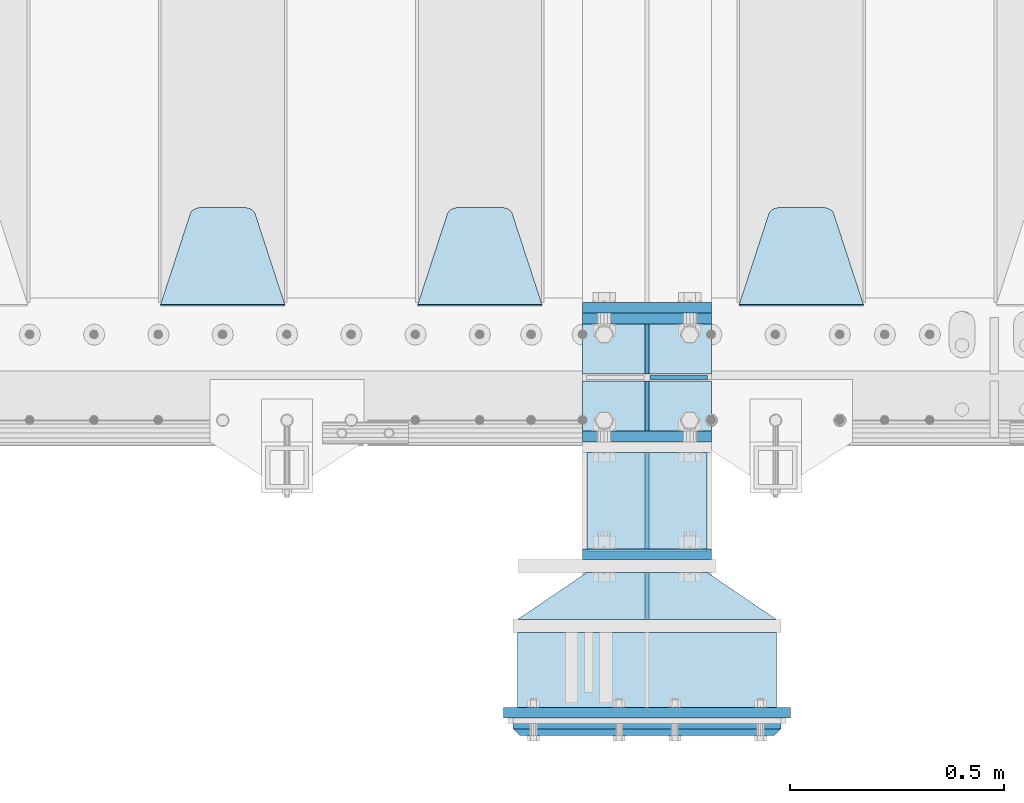
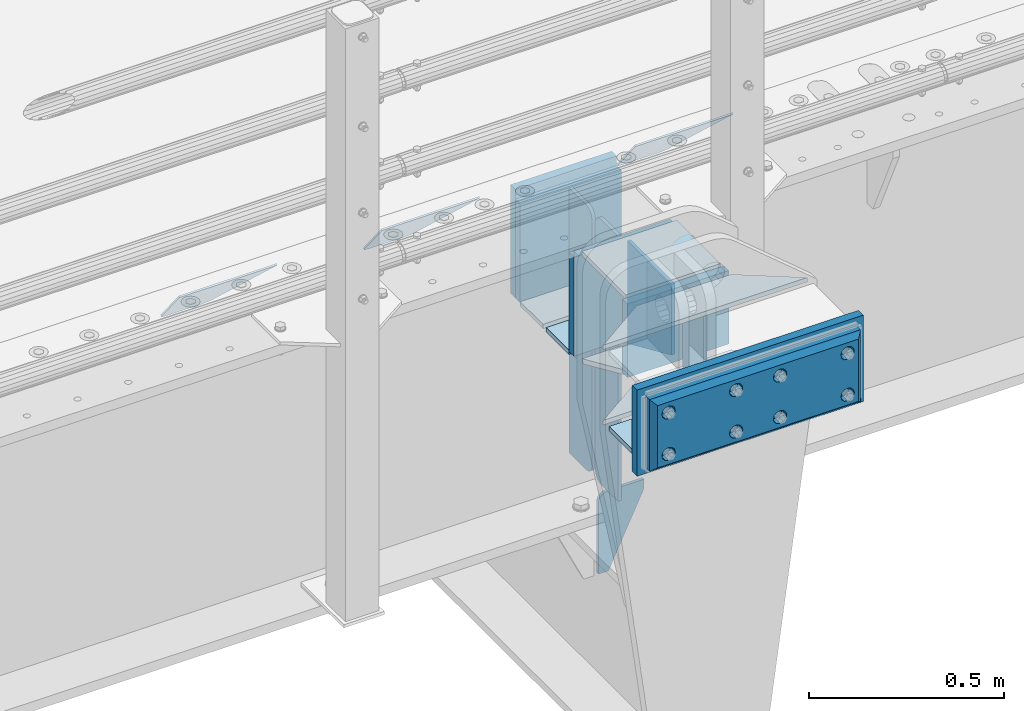
# One storey, part 199 of 240: 23 plates.
"""IFC2X3 building model written with IfcOpenShell, lengths in millimetres."""

from ifc_helpers import new_model, si_unit, frame, origin_with_axes, place, context, subcontext, project, spatial, faceted_brep, material, type_object, element, save


model = new_model("IFC2X3")

# Units and contexts
model_context = context("Model", 3, precision=1e-05, world=origin_with_axes())
body_context = subcontext(model_context, "Body", "Model", "MODEL_VIEW")
ifc_project = project(units=[si_unit("LENGTHUNIT", "METRE", prefix="MILLI"), si_unit("AREAUNIT", "SQUARE_METRE"), si_unit("VOLUMEUNIT", "CUBIC_METRE"), si_unit("MASSUNIT", "GRAM", prefix="KILO"), si_unit("TIMEUNIT", "SECOND"), si_unit("PLANEANGLEUNIT", "RADIAN"), si_unit("SOLIDANGLEUNIT", "STERADIAN"), si_unit("THERMODYNAMICTEMPERATUREUNIT", "DEGREE_CELSIUS"), si_unit("LUMINOUSINTENSITYUNIT", "LUMEN")], contexts=[model_context])

# Site, building, storey
site_placement = place(None, origin_with_axes())
site = spatial("IfcSite", under=ifc_project, at=site_placement, CompositionType="ELEMENT")
building_placement = place(site_placement, origin_with_axes())
building = spatial("IfcBuilding", under=site, at=building_placement, Name="Standard", CompositionType="ELEMENT")
storey_placement = place(building_placement, origin_with_axes())
storey = spatial("IfcBuildingStorey", under=building, at=storey_placement, Name="Undefined", CompositionType="ELEMENT", Elevation=0.0)

# Plates
ifc_material_1 = material(Name="STEEL/S355N")
plate_type_1 = type_object("IfcPlateType", PredefinedType="NOTDEFINED")
plate_1_placement = place(storey_placement, frame((52690.0, 24162.5, -340.000000000044), z_axis=(0.0, 0.0, 1.0), x_axis=(1.0, 0.0, 0.0)))
element("IfcPlate", 1, at=plate_1_placement, inside=storey, type_object=plate_type_1, material=ifc_material_1, context=body_context, shape_type="Brep", body=[
    faceted_brep([(0.0, -12.5, 0.0), (9.31322574615479e-10, -12.5, 340.0), (9.31322574615479e-10, 12.5, 340.0), (0.0, 12.5, 0.0), (300.0, -12.5, 340.0), (300.0, 12.5, 340.0), (300.0, -12.5, 0.0), (300.0, 12.5, 0.0)], [[[0, 1, 2, 3]], [[1, 4, 5, 2]], [[4, 6, 7, 5]], [[6, 0, 3, 7]], [[5, 7, 3, 2]], [[6, 4, 1, 0]]]),
])
for number, where, z_axis, x_axis in (
    (2, (52690.0, 23862.5, -340.0), (0.0, 0.0, 1.0), (1.0, 0.0, 0.0)),
    (3, (52690.0, 24137.5, -340.0), (0.0, 0.0, 1.0), (1.0, 0.0, 0.0)),
):
    element("IfcPlate", number, at=place(storey_placement, frame(where, z_axis=z_axis, x_axis=x_axis)), inside=storey, type_object=plate_type_1, material=ifc_material_1, context=body_context, shape_type="Brep", body=[
        faceted_brep([(0.0, -12.5, 0.0), (0.0, -12.5, 310.0), (0.0, 12.5, 310.0), (0.0, 12.5, 0.0), (300.0, -12.5, 310.0), (300.0, 12.5, 310.0), (300.0, -12.5, 0.0), (300.0, 12.5, 0.0)], [[[0, 1, 2, 3]], [[1, 4, 5, 2]], [[4, 6, 7, 5]], [[6, 0, 3, 7]], [[5, 7, 3, 2]], [[6, 4, 1, 0]]]),
    ])
plate_type_2 = type_object("IfcPlateType", PredefinedType="NOTDEFINED")
for number, where, z_axis, x_axis in (
    (4, (52690.0, 24008.0, -343.0), (0.0, 1.0, 0.0), (1.0, 0.0, 0.0)),
    (5, (52690.0, 23992.0, -343.0), (0.0, -1.0, 0.0), (1.0, 0.0, 0.0)),
):
    element("IfcPlate", number, at=place(storey_placement, frame(where, z_axis=z_axis, x_axis=x_axis)), inside=storey, type_object=plate_type_2, material=ifc_material_1, context=body_context, shape_type="Brep", body=[
        faceted_brep([(0.0, -7.0, 0.0), (0.0, -7.0, 117.0), (0.0, 7.0, 117.0), (0.0, 7.0, 0.0), (300.0, -7.0, 117.0), (300.0, 7.0, 117.0), (300.0, -7.0, 0.0), (300.0, 7.0, 0.0)], [[[0, 1, 2, 3]], [[1, 4, 5, 2]], [[4, 6, 7, 5]], [[6, 0, 3, 7]], [[5, 7, 3, 2]], [[6, 4, 1, 0]]]),
    ])
plate_type_3 = type_object("IfcPlateType", PredefinedType="NOTDEFINED")
for number, where, z_axis, x_axis in (
    (6, (52840.0, 23992.0, -30.0), (0.0, 0.0, -1.0), (0.0, -1.0, 0.0)),
    (7, (52840.0, 24008.0, -30.0), (0.0, 0.0, -1.0), (0.0, 1.0, 0.0)),
):
    element("IfcPlate", number, at=place(storey_placement, frame(where, z_axis=z_axis, x_axis=x_axis)), inside=storey, type_object=plate_type_3, material=ifc_material_1, context=body_context, shape_type="Brep", body=[
        faceted_brep([(0.0, -5.0, 30.0), (0.0, -5.0, 306.0), (0.0, 5.0, 306.0), (0.0, 5.0, 30.0), (117.0, -5.0, 306.0), (117.0, 5.0, 306.0), (117.0, -5.0, 0.0), (117.0, 5.0, 0.0), (30.0, -5.0, 0.0), (30.0, 5.0, 0.0), (24.7905546699913, -5.0, 0.455767409633758), (24.7905546699913, 5.0, 0.455767409633758), (19.7393957002278, -5.0, 1.80922137642275), (19.7393957002278, 5.0, 1.80922137642275), (15.0, -5.0, 4.01923788646684), (15.0, 5.0, 4.01923788646684), (10.7163717094008, -5.0, 7.01866670643066), (10.7163717094008, 5.0, 7.01866670643066), (7.01866670643358, -5.0, 10.7163717094038), (7.01866670643358, 5.0, 10.7163717094038), (4.01923788646673, -5.0, 15.0), (4.01923788646673, 5.0, 15.0), (1.80922137642483, -5.0, 19.7393957002299), (1.80922137642483, 5.0, 19.7393957002299), (0.455767409635882, -5.0, 24.7905546699921), (0.455767409635882, 5.0, 24.7905546699921)], [[[0, 1, 2, 3]], [[1, 4, 5, 2]], [[4, 6, 7, 5]], [[6, 8, 9, 7]], [[8, 10, 11, 9]], [[10, 12, 13, 11]], [[12, 14, 15, 13]], [[14, 16, 17, 15]], [[16, 18, 19, 17]], [[18, 20, 21, 19]], [[20, 22, 23, 21]], [[22, 24, 25, 23]], [[24, 0, 3, 25]], [[5, 7, 9, 11, 13, 15, 17, 19, 21, 23, 25, 3, 2]], [[24, 22, 20, 18, 16, 14, 12, 10, 8, 6, 4, 1, 0]]]),
    ])
for number, where, z_axis, x_axis in (
    (8, (52840.0, 23992.0, -350.0), (0.0, 0.0, -1.0), (0.0, -1.0, 0.0)),
    (9, (52840.0, 24008.0, -350.0), (0.0, 0.0, -1.0), (0.0, 1.0, 0.0)),
):
    element("IfcPlate", number, at=place(storey_placement, frame(where, z_axis=z_axis, x_axis=x_axis)), inside=storey, type_object=plate_type_3, material=ifc_material_1, context=body_context, shape_type="Brep", body=[
        faceted_brep([(0.0, -5.0, 0.0), (0.0, -5.0, 480.0), (0.0, 5.0, 480.0), (0.0, 5.0, 0.0), (0.455767409635882, -5.0, 485.209445330008), (0.455767409635882, 5.0, 485.209445330008), (1.80922137642483, -5.0, 490.26060429977), (1.80922137642483, 5.0, 490.26060429977), (4.01923788646673, -5.0, 495.0), (4.01923788646673, 5.0, 495.0), (7.01866670643358, -5.0, 499.283628290596), (7.01866670643358, 5.0, 499.283628290596), (10.7163717094008, -5.0, 502.981333293569), (10.7163717094008, 5.0, 502.981333293569), (15.0, -5.0, 505.980762113533), (15.0, 5.0, 505.980762113533), (19.7393957002278, -5.0, 508.190778623577), (19.7393957002278, 5.0, 508.190778623577), (24.7905546699913, -5.0, 509.544232590366), (24.7905546699913, 5.0, 509.544232590366), (30.0, -5.0, 510.0), (30.0, 5.0, 510.0), (117.0, -5.0, 510.0), (117.0, 5.0, 510.0), (117.0, -5.0, 0.0), (117.0, 5.0, 0.0)], [[[0, 1, 2, 3]], [[1, 4, 5, 2]], [[4, 6, 7, 5]], [[6, 8, 9, 7]], [[8, 10, 11, 9]], [[10, 12, 13, 11]], [[12, 14, 15, 13]], [[14, 16, 17, 15]], [[16, 18, 19, 17]], [[18, 20, 21, 19]], [[20, 22, 23, 21]], [[22, 24, 25, 23]], [[24, 0, 3, 25]], [[5, 7, 9, 11, 13, 15, 17, 19, 21, 23, 25, 3, 2]], [[24, 22, 20, 18, 16, 14, 12, 10, 8, 6, 4, 1, 0]]]),
    ])
plate_type_4 = type_object("IfcPlateType", PredefinedType="NOTDEFINED")
plate_2_placement = place(storey_placement, frame((52846.5, 24000.0000000345, -915.000018222274), z_axis=(0.0, 0.0, -1.0), x_axis=(1.0, 0.0, 0.0)))
element("IfcPlate", 10, at=plate_2_placement, inside=storey, type_object=plate_type_4, material=ifc_material_1, context=body_context, shape_type="Brep", body=[
    faceted_brep([(0.0, -5.0, 27.0), (0.0, -5.0, 250.0), (0.0, 5.0, 250.0), (0.0, 5.0, 27.0), (30.0, -5.0, 250.0), (30.0, 5.0, 250.0), (135.0, -5.0, 30.0), (135.0, 5.0, 30.0), (135.0, -5.0, 0.0), (135.0, 5.0, 0.0), (27.0, -5.0, 0.0), (27.0, 5.0, 0.0), (22.311499202995, -5.0, 0.410190668670339), (22.311499202995, 5.0, 0.410190668670339), (17.7654561302043, -5.0, 1.62829923878053), (17.7654561302043, 5.0, 1.62829923878053), (13.5, -5.0, 3.6173140978201), (13.5, 5.0, 3.6173140978201), (9.64473453846585, -5.0, 6.31680003578754), (9.64473453846585, 5.0, 6.31680003578754), (6.31680003579095, -5.0, 9.64473453846347), (6.31680003579095, 5.0, 9.64473453846347), (3.61731409782078, -5.0, 13.5), (3.61731409782078, 5.0, 13.5), (1.62829923877871, -5.0, 17.765456130207), (1.62829923877871, 5.0, 17.765456130207), (0.410190668670111, -5.0, 22.3114992029929), (0.410190668670111, 5.0, 22.3114992029929)], [[[0, 1, 2, 3]], [[1, 4, 5, 2]], [[4, 6, 7, 5]], [[6, 8, 9, 7]], [[8, 10, 11, 9]], [[10, 12, 13, 11]], [[12, 14, 15, 13]], [[14, 16, 17, 15]], [[16, 18, 19, 17]], [[18, 20, 21, 19]], [[20, 22, 23, 21]], [[22, 24, 25, 23]], [[24, 26, 27, 25]], [[26, 0, 3, 27]], [[5, 7, 9, 11, 13, 15, 17, 19, 21, 23, 25, 27, 3, 2]], [[26, 24, 22, 20, 18, 16, 14, 12, 10, 8, 6, 4, 1, 0]]]),
])
plate_type_5 = type_object("IfcPlateType", PredefinedType="NOTDEFINED")
plate_3_placement = place(storey_placement, frame((53345.0, 24168.232233047, -1.76776695296758), z_axis=(0.0, 0.707106781186547, -0.707106781186548), x_axis=(-1.0, 0.0, 0.0)))
element("IfcPlate", 11, at=plate_3_placement, inside=storey, type_object=plate_type_5, material=ifc_material_1, context=body_context, shape_type="Brep", body=[
    faceted_brep([(0.0, -2.5, 0.0), (69.345504679477, -2.50000000000364, 300.171731424827), (69.345504679477, 2.49999999999636, 300.171731424827), (0.0, 2.5, 0.0), (70.927406119954, -2.50000000000364, 304.897442415397), (70.927406119954, 2.49999999999636, 304.897442415397), (73.3818627772271, -2.50000000000728, 309.234538108525), (73.3818627772271, 2.49999999999636, 309.234538108529), (76.6187032999587, -2.50000000000728, 313.023683126099), (76.6187032999587, 2.49999999999636, 313.023683126103), (80.5190132705029, -2.50000000000364, 316.125672595368), (80.5190132705029, 2.49999999999636, 316.125672595368), (84.9395038596849, -2.50000000000364, 318.426546230472), (84.9395038596849, 2.49999999999636, 318.426546230472), (89.7177759439219, -2.5, 319.841774983277), (89.7177759439219, 2.49999999999636, 319.841774983273), (94.6782862926484, -2.50000000000364, 320.319366455074), (94.6782862926484, 2.49999999999636, 320.319366455074), (195.321713707352, -2.50000000000364, 320.319366455074), (195.321713707352, 2.49999999999636, 320.319366455074), (200.282224056078, -2.50000000000364, 319.841774983273), (200.282224056078, 2.49999999999636, 319.841774983273), (205.060496140315, -2.50000000000364, 318.426546230472), (205.060496140315, 2.49999999999636, 318.426546230472), (209.480986729497, -2.50000000000364, 316.125672595368), (209.480986729497, 2.49999999999636, 316.125672595368), (213.381296700041, -2.50000000000728, 313.023683126099), (213.381296700041, 2.49999999999272, 313.023683126099), (216.618137222766, -2.50000000000364, 309.234538108522), (216.618137222766, 2.49999999999636, 309.234538108522), (219.072593880039, -2.50000000000364, 304.897442415397), (219.072593880039, 2.49999999999636, 304.897442415397), (220.654495320523, -2.50000000000364, 300.171731424827), (220.654495320523, 2.49999999999636, 300.171731424827), (290.0, -2.50000000000364, -3.63797880709171e-12), (290.0, 2.49999999999636, -3.63797880709171e-12)], [[[0, 1, 2, 3]], [[1, 4, 5, 2]], [[4, 6, 7, 5]], [[6, 8, 9, 7]], [[8, 10, 11, 9]], [[10, 12, 13, 11]], [[12, 14, 15, 13]], [[14, 16, 17, 15]], [[16, 18, 19, 17]], [[18, 20, 21, 19]], [[20, 22, 23, 21]], [[22, 24, 25, 23]], [[24, 26, 27, 25]], [[26, 28, 29, 27]], [[28, 30, 31, 29]], [[30, 32, 33, 31]], [[32, 34, 35, 33]], [[34, 0, 3, 35]], [[5, 7, 9, 11, 13, 15, 17, 19, 21, 23, 25, 27, 29, 31, 33, 35, 3, 2]], [[34, 32, 30, 28, 26, 24, 22, 20, 18, 16, 14, 12, 10, 8, 6, 4, 1, 0]]]),
])
plate_4_placement = place(storey_placement, frame((52595.0, 24168.232233047, -1.76776695296758), z_axis=(0.0, 0.707106781186547, -0.707106781186548), x_axis=(-1.0, 0.0, 0.0)))
element("IfcPlate", 12, at=plate_4_placement, inside=storey, type_object=plate_type_5, material=ifc_material_1, context=body_context, shape_type="Brep", body=[
    faceted_brep([(0.0, -2.5, 0.0), (69.345504679477, -2.50000000000364, 300.171731424827), (69.345504679477, 2.49999999999636, 300.171731424827), (0.0, 2.5, 0.0), (70.927406119954, -2.50000000000364, 304.897442415397), (70.927406119954, 2.49999999999636, 304.897442415397), (73.3818627772271, -2.50000000000728, 309.234538108525), (73.3818627772271, 2.49999999999636, 309.234538108529), (76.6187032999587, -2.50000000000728, 313.023683126099), (76.6187032999587, 2.49999999999636, 313.023683126103), (80.5190132705029, -2.50000000000364, 316.125672595368), (80.5190132705029, 2.49999999999636, 316.125672595368), (84.9395038596849, -2.50000000000364, 318.426546230472), (84.9395038596849, 2.49999999999636, 318.426546230472), (89.7177759439219, -2.5, 319.841774983277), (89.7177759439219, 2.49999999999636, 319.841774983273), (94.6782862926484, -2.50000000000364, 320.319366455074), (94.6782862926484, 2.49999999999636, 320.319366455074), (195.321713707352, -2.50000000000364, 320.319366455074), (195.321713707352, 2.49999999999636, 320.319366455074), (200.282224056078, -2.50000000000364, 319.841774983273), (200.282224056078, 2.49999999999636, 319.841774983273), (205.060496140315, -2.50000000000364, 318.426546230472), (205.060496140315, 2.49999999999636, 318.426546230472), (209.480986729497, -2.50000000000364, 316.125672595368), (209.480986729497, 2.49999999999636, 316.125672595368), (213.381296700041, -2.50000000000728, 313.023683126099), (213.381296700041, 2.49999999999272, 313.023683126099), (216.618137222766, -2.50000000000364, 309.234538108522), (216.618137222766, 2.49999999999636, 309.234538108522), (219.072593880039, -2.50000000000364, 304.897442415397), (219.072593880039, 2.49999999999636, 304.897442415397), (220.654495320523, -2.50000000000364, 300.171731424827), (220.654495320523, 2.49999999999636, 300.171731424827), (290.0, -2.50000000000364, -3.63797880709171e-12), (290.0, 2.49999999999636, -3.63797880709171e-12)], [[[0, 1, 2, 3]], [[1, 4, 5, 2]], [[4, 6, 7, 5]], [[6, 8, 9, 7]], [[8, 10, 11, 9]], [[10, 12, 13, 11]], [[12, 14, 15, 13]], [[14, 16, 17, 15]], [[16, 18, 19, 17]], [[18, 20, 21, 19]], [[20, 22, 23, 21]], [[22, 24, 25, 23]], [[24, 26, 27, 25]], [[26, 28, 29, 27]], [[28, 30, 31, 29]], [[30, 32, 33, 31]], [[32, 34, 35, 33]], [[34, 0, 3, 35]], [[5, 7, 9, 11, 13, 15, 17, 19, 21, 23, 25, 27, 29, 31, 33, 35, 3, 2]], [[34, 32, 30, 28, 26, 24, 22, 20, 18, 16, 14, 12, 10, 8, 6, 4, 1, 0]]]),
])
plate_5_placement = place(storey_placement, frame((51995.0, 24168.232233047, -1.76776695296758), z_axis=(0.0, 0.707106781186547, -0.707106781186548), x_axis=(-1.0, 0.0, 0.0)))
element("IfcPlate", 13, at=plate_5_placement, inside=storey, type_object=plate_type_5, material=ifc_material_1, context=body_context, shape_type="Brep", body=[
    faceted_brep([(0.0, -2.5, 0.0), (69.345504679477, -2.50000000000364, 300.171731424827), (69.345504679477, 2.49999999999636, 300.171731424827), (0.0, 2.5, 0.0), (70.927406119954, -2.50000000000364, 304.897442415397), (70.927406119954, 2.49999999999636, 304.897442415397), (73.3818627772271, -2.50000000000728, 309.234538108525), (73.3818627772271, 2.49999999999636, 309.234538108529), (76.6187032999587, -2.50000000000728, 313.023683126099), (76.6187032999587, 2.49999999999636, 313.023683126103), (80.5190132705029, -2.50000000000364, 316.125672595368), (80.5190132705029, 2.49999999999636, 316.125672595368), (84.9395038596849, -2.50000000000364, 318.426546230472), (84.9395038596849, 2.49999999999636, 318.426546230472), (89.7177759439219, -2.5, 319.841774983277), (89.7177759439219, 2.49999999999636, 319.841774983273), (94.6782862926484, -2.50000000000364, 320.319366455074), (94.6782862926484, 2.49999999999636, 320.319366455074), (195.321713707352, -2.50000000000364, 320.319366455074), (195.321713707352, 2.49999999999636, 320.319366455074), (200.282224056078, -2.50000000000364, 319.841774983273), (200.282224056078, 2.49999999999636, 319.841774983273), (205.060496140315, -2.50000000000364, 318.426546230472), (205.060496140315, 2.49999999999636, 318.426546230472), (209.480986729497, -2.50000000000364, 316.125672595368), (209.480986729497, 2.49999999999636, 316.125672595368), (213.381296700041, -2.50000000000728, 313.023683126099), (213.381296700041, 2.49999999999272, 313.023683126099), (216.618137222766, -2.50000000000364, 309.234538108522), (216.618137222766, 2.49999999999636, 309.234538108522), (219.072593880039, -2.50000000000364, 304.897442415397), (219.072593880039, 2.49999999999636, 304.897442415397), (220.654495320523, -2.50000000000364, 300.171731424827), (220.654495320523, 2.49999999999636, 300.171731424827), (290.0, -2.50000000000364, -3.63797880709171e-12), (290.0, 2.49999999999636, -3.63797880709171e-12)], [[[0, 1, 2, 3]], [[1, 4, 5, 2]], [[4, 6, 7, 5]], [[6, 8, 9, 7]], [[8, 10, 11, 9]], [[10, 12, 13, 11]], [[12, 14, 15, 13]], [[14, 16, 17, 15]], [[16, 18, 19, 17]], [[18, 20, 21, 19]], [[20, 22, 23, 21]], [[22, 24, 25, 23]], [[24, 26, 27, 25]], [[26, 28, 29, 27]], [[28, 30, 31, 29]], [[30, 32, 33, 31]], [[32, 34, 35, 33]], [[34, 0, 3, 35]], [[5, 7, 9, 11, 13, 15, 17, 19, 21, 23, 25, 27, 29, 31, 33, 35, 3, 2]], [[34, 32, 30, 28, 26, 24, 22, 20, 18, 16, 14, 12, 10, 8, 6, 4, 1, 0]]]),
])
ifc_material_2 = material()
plate_type_6 = type_object("IfcPlateType", PredefinedType="NOTDEFINED")
plate_6_placement = place(storey_placement, frame((53142.5, 23405.0000000345, -243.000018222276), z_axis=(0.0, -1.0, 0.0), x_axis=(-1.0, 0.0, 0.0)))
element("IfcPlate", 14, at=plate_6_placement, inside=storey, type_object=plate_type_6, material=ifc_material_2, context=body_context, shape_type="Brep", body=[
    faceted_brep([(0.0, -7.0, 0.0), (0.0, -7.0, 175.0), (0.0, 7.0, 175.0), (0.0, 7.0, 0.0), (605.0, -7.0, 175.0), (605.0, 7.0, 175.0), (605.0, -7.0, 0.0), (605.0, 7.0, 0.0)], [[[0, 1, 2, 3]], [[1, 4, 5, 2]], [[4, 6, 7, 5]], [[6, 0, 3, 7]], [[5, 7, 3, 2]], [[6, 4, 1, 0]]]),
])
plate_type_7 = type_object("IfcPlateType", PredefinedType="NOTDEFINED")
plate_7_placement = place(storey_placement, frame((53175.0, 23217.5000000345, 9.9999817777242), z_axis=(0.0, 0.0, -1.0), x_axis=(-1.0, 0.0, 0.0)))
element("IfcPlate", 15, at=plate_7_placement, inside=storey, type_object=plate_type_7, material=ifc_material_1, context=body_context, shape_type="Brep", body=[
    faceted_brep([(0.0, -12.5, 0.0), (0.0, -12.5, 270.0), (0.0, 12.5, 270.0), (0.0, 12.5, 0.0), (670.0, -12.5, 270.0), (670.0, 12.5, 270.0), (670.0, -12.5, 0.0), (670.0, 12.5, 0.0)], [[[0, 1, 2, 3]], [[1, 4, 5, 2]], [[4, 6, 7, 5]], [[6, 0, 3, 7]], [[5, 7, 3, 2]], [[6, 4, 1, 0]]]),
])
plate_type_8 = type_object("IfcPlateType", PredefinedType="NOTDEFINED")
for number, where, z_axis, x_axis in (
    (16, (53142.5, 23435.0000000345, -243.000018222276), (-0.560566412034006, -0.828109472050236, 0.0), (-0.828109472050235, 0.560566412034008, 0.0)),
    (17, (53142.5, 23435.0000000345, -7.0000182222758), (-0.560566412034006, -0.828109472050236, 0.0), (-0.828109472050235, 0.560566412034008, 0.0)),
):
    element("IfcPlate", number, at=place(storey_placement, frame(where, z_axis=z_axis, x_axis=x_axis)), inside=storey, type_object=plate_type_8, material=ifc_material_1, context=body_context, shape_type="Brep", body=[
        faceted_brep([(0.0, -7.0, 0.0), (501.006225585945, -7.0, 339.142669677733), (501.006225585945, 7.0, 339.142669677733), (0.0, 7.0, 0.0), (428.100738525383, -7.0, 156.958602905272), (428.100738525383, 7.0, 156.958602905272), (196.230087280266, -7.0, -4.34624780609738e-10), (196.230087280266, 7.0, -4.34624780609738e-10)], [[[0, 1, 2, 3]], [[1, 4, 5, 2]], [[4, 6, 7, 5]], [[6, 0, 3, 7]], [[5, 7, 3, 2]], [[6, 4, 1, 0]]]),
    ])
plate_type_9 = type_object("IfcPlateType", PredefinedType="NOTDEFINED")
plate_8_placement = place(storey_placement, frame((52840.0, 23435.0000000345, -14.0000182222758), z_axis=(0.0, 0.0, -1.0), x_axis=(0.0, 1.0, 0.0)))
element("IfcPlate", 18, at=plate_8_placement, inside=storey, type_object=plate_type_9, material=ifc_material_1, context=body_context, shape_type="Brep", body=[
    faceted_brep([(0.0, -5.0, 0.0), (0.0, -5.0, 222.0), (0.0, 5.0, 222.0), (0.0, 5.0, 0.0), (110.0, -5.0, 222.0), (110.0, 5.0, 222.0), (110.0, -5.0, 0.0), (110.0, 5.0, 0.0)], [[[0, 1, 2, 3]], [[1, 4, 5, 2]], [[4, 6, 7, 5]], [[6, 0, 3, 7]], [[5, 7, 3, 2]], [[6, 4, 1, 0]]]),
])
plate_type_10 = type_object("IfcPlateType", PredefinedType="NOTDEFINED")
plate_9_placement = place(storey_placement, frame((52700.0, 23822.1570307734, -342.396699063199), z_axis=(0.0, -0.913811548702731, 0.406138465867881), x_axis=(1.0, 0.0, 0.0)))
element("IfcPlate", 19, at=plate_9_placement, inside=storey, type_object=plate_type_10, material=ifc_material_1, context=body_context, shape_type="Brep", body=[
    faceted_brep([(0.0, -7.0, 0.0), (0.0, -7.0, 246.221450805664), (0.0, 7.0, 246.221450805664), (0.0, 7.0, 0.0), (280.0, -7.0, 246.221450805664), (280.0, 7.0, 246.221450805664), (280.0, -6.99999999999818, 0.0), (280.0, 7.0, 0.0)], [[[0, 1, 2, 3]], [[1, 4, 5, 2]], [[4, 6, 7, 5]], [[6, 0, 3, 7]], [[5, 7, 3, 2]], [[6, 4, 1, 0]]]),
])
ifc_material_3 = material()
plate_type_11 = type_object("IfcPlateType", PredefinedType="NOTDEFINED")
plate_10_placement = place(storey_placement, frame((53152.5, 23185.0000000345, -12.5000182222758), z_axis=(0.0, 0.0, -1.0), x_axis=(-1.0, 0.0, 0.0)))
element("IfcPlate", 20, at=plate_10_placement, inside=storey, type_object=plate_type_11, material=ifc_material_3, context=body_context, shape_type="Brep", body=[
    faceted_brep([(0.0, -5.0, 0.0), (15.0, -20.0, 15.0), (15.0, -20.0, 210.0), (0.0, -5.0, 225.0), (625.0, -5.0, 225.0), (610.0, -20.0, 210.0), (610.0, -20.0, 15.0), (625.0, -5.0, 0.0), (625.0, 15.0, 0.0), (620.0, 20.0, 5.0), (620.0, 20.0, 220.0), (625.0, 15.0, 225.0), (0.0, 15.0, 225.0), (5.0, 20.0, 220.0), (5.0, 20.0, 5.0), (0.0, 15.0, 0.0), (30.1794919243112, 5.0, 167.499999999998), (37.5, 5.0, 160.179491924309), (47.5, 5.0, 157.499999999998), (57.5, 5.0, 160.179491924309), (64.8205080756888, 5.0, 167.499999999998), (67.5, 5.0, 177.499999999998), (64.8205080756888, 5.0, 187.499999999998), (57.5, 5.0, 194.820508075687), (47.5, 5.0, 197.499999999998), (37.5, 5.0, 194.820508075687), (30.1794919243112, 5.0, 187.499999999998), (27.5, 5.0, 177.499999999998), (37.5, -20.0, 160.179491924309), (30.1794919243112, -20.0, 167.499999999998), (47.5, -20.0, 157.499999999998), (57.5, -20.0, 160.179491924309), (64.8205080756888, -20.0, 167.499999999998), (67.5, -20.0, 177.499999999998), (64.8205080756888, -20.0, 187.499999999998), (57.5, -20.0, 194.820508075687), (47.5, -20.0, 197.499999999998), (37.5, -20.0, 194.820508075687), (30.1794919243112, -20.0, 187.499999999998), (27.5, -20.0, 177.499999999998), (30.1794919243112, 5.0, 37.4999999999982), (37.5, 5.0, 30.1794919243094), (47.5, 5.0, 27.4999999999982), (57.5, 5.0, 30.1794919243094), (64.8205080756888, 5.0, 37.4999999999982), (67.5, 5.0, 47.4999999999982), (64.8205080756888, 5.0, 57.4999999999982), (57.5, 5.0, 64.8205080756869), (47.5, 5.0, 67.4999999999982), (37.5, 5.0, 64.820508075687), (30.1794919243112, 5.0, 57.4999999999982), (27.5, 5.0, 47.4999999999982), (30.1794919243112, -20.0, 37.4999999999982), (27.5, -20.0, 47.4999999999982), (37.5, -20.0, 30.1794919243094), (47.5, -20.0, 27.4999999999982), (57.5, -20.0, 30.1794919243094), (64.8205080756888, -20.0, 37.4999999999982), (67.5, -20.0, 47.4999999999982), (64.8205080756888, -20.0, 57.4999999999982), (57.5, -20.0, 64.8205080756869), (47.5, -20.0, 67.4999999999982), (37.5, -20.0, 64.820508075687), (30.1794919243112, -20.0, 57.4999999999982), (230.179491924311, 5.0, 37.4999999999982), (237.5, 5.0, 30.1794919243094), (247.5, 5.0, 27.4999999999982), (257.5, 5.0, 30.1794919243094), (264.820508075689, 5.0, 37.4999999999982), (267.5, 5.0, 47.4999999999982), (264.820508075689, 5.0, 57.4999999999982), (257.5, 5.0, 64.8205080756869), (247.5, 5.0, 67.4999999999982), (237.5, 5.0, 64.820508075687), (230.179491924311, 5.0, 57.4999999999982), (227.5, 5.0, 47.4999999999982), (230.179491924311, -20.0, 37.4999999999982), (227.5, -20.0, 47.4999999999982), (237.5, -20.0, 30.1794919243094), (247.5, -20.0, 27.4999999999982), (257.5, -20.0, 30.1794919243094), (264.820508075689, -20.0, 37.4999999999982), (267.5, -20.0, 47.4999999999982), (264.820508075689, -20.0, 57.4999999999982), (257.5, -20.0, 64.8205080756869), (247.5, -20.0, 67.4999999999982), (237.5, -20.0, 64.820508075687), (230.179491924311, -20.0, 57.4999999999982), (360.179491924311, 5.0, 37.4999999999982), (367.5, 5.0, 30.1794919243094), (377.5, 5.0, 27.4999999999982), (387.5, 5.0, 30.1794919243094), (394.820508075689, 5.0, 37.4999999999982), (397.5, 5.0, 47.4999999999982), (394.820508075689, 5.0, 57.4999999999982), (387.5, 5.0, 64.8205080756869), (377.5, 5.0, 67.4999999999982), (367.5, 5.0, 64.820508075687), (360.179491924311, 5.0, 57.4999999999982), (357.5, 5.0, 47.4999999999982), (360.179491924311, -20.0, 37.4999999999982), (357.5, -20.0, 47.4999999999982), (367.5, -20.0, 30.1794919243094), (377.5, -20.0, 27.4999999999982), (387.5, -20.0, 30.1794919243094), (394.820508075689, -20.0, 37.4999999999982), (397.5, -20.0, 47.4999999999982), (394.820508075689, -20.0, 57.4999999999982), (387.5, -20.0, 64.8205080756869), (377.5, -20.0, 67.4999999999982), (367.5, -20.0, 64.820508075687), (360.179491924311, -20.0, 57.4999999999982), (560.179491924311, 5.0, 37.4999999999982), (567.5, 5.0, 30.1794919243094), (577.5, 5.0, 27.4999999999982), (587.5, 5.0, 30.1794919243094), (594.820508075689, 5.0, 37.4999999999982), (597.5, 5.0, 47.4999999999982), (594.820508075689, 5.0, 57.4999999999982), (587.5, 5.0, 64.8205080756869), (577.5, 5.0, 67.4999999999982), (567.5, 5.0, 64.820508075687), (560.179491924311, 5.0, 57.4999999999982), (557.5, 5.0, 47.4999999999982), (560.179491924311, -20.0, 37.4999999999982), (557.5, -20.0, 47.4999999999982), (567.5, -20.0, 30.1794919243094), (577.5, -20.0, 27.4999999999982), (587.5, -20.0, 30.1794919243094), (594.820508075689, -20.0, 37.4999999999982), (597.5, -20.0, 47.4999999999982), (594.820508075689, -20.0, 57.4999999999982), (587.5, -20.0, 64.8205080756869), (577.5, -20.0, 67.4999999999982), (567.5, -20.0, 64.820508075687), (560.179491924311, -20.0, 57.4999999999982), (560.179491924311, 5.0, 167.499999999998), (567.5, 5.0, 160.179491924309), (577.5, 5.0, 157.499999999998), (587.5, 5.0, 160.179491924309), (594.820508075689, 5.0, 167.499999999998), (597.5, 5.0, 177.499999999998), (594.820508075689, 5.0, 187.499999999998), (587.5, 5.0, 194.820508075687), (577.5, 5.0, 197.499999999998), (567.5, 5.0, 194.820508075687), (560.179491924311, 5.0, 187.499999999998), (557.5, 5.0, 177.499999999998), (560.179491924311, -20.0, 167.499999999998), (557.5, -20.0, 177.499999999998), (567.5, -20.0, 160.179491924309), (577.5, -20.0, 157.499999999998), (587.5, -20.0, 160.179491924309), (594.820508075689, -20.0, 167.499999999998), (597.5, -20.0, 177.499999999998), (594.820508075689, -20.0, 187.499999999998), (587.5, -20.0, 194.820508075687), (577.5, -20.0, 197.499999999998), (567.5, -20.0, 194.820508075687), (560.179491924311, -20.0, 187.499999999998), (360.179491924311, 5.0, 167.499999999998), (367.5, 5.0, 160.179491924309), (377.5, 5.0, 157.499999999998), (387.5, 5.0, 160.179491924309), (394.820508075689, 5.0, 167.499999999998), (397.5, 5.0, 177.499999999998), (394.820508075689, 5.0, 187.499999999998), (387.5, 5.0, 194.820508075687), (377.5, 5.0, 197.499999999998), (367.5, 5.0, 194.820508075687), (360.179491924311, 5.0, 187.499999999998), (357.5, 5.0, 177.499999999998), (360.179491924311, -20.0, 167.499999999998), (357.5, -20.0, 177.499999999998), (367.5, -20.0, 160.179491924309), (377.5, -20.0, 157.499999999998), (387.5, -20.0, 160.179491924309), (394.820508075689, -20.0, 167.499999999998), (397.5, -20.0, 177.499999999998), (394.820508075689, -20.0, 187.499999999998), (387.5, -20.0, 194.820508075687), (377.5, -20.0, 197.499999999998), (367.5, -20.0, 194.820508075687), (360.179491924311, -20.0, 187.499999999998), (230.179491924311, 5.0, 167.499999999998), (237.5, 5.0, 160.179491924309), (247.5, 5.0, 157.499999999998), (257.5, 5.0, 160.179491924309), (264.820508075689, 5.0, 167.499999999998), (267.5, 5.0, 177.499999999998), (264.820508075689, 5.0, 187.499999999998), (257.5, 5.0, 194.820508075687), (247.5, 5.0, 197.499999999998), (237.5, 5.0, 194.820508075687), (230.179491924311, 5.0, 187.499999999998), (227.5, 5.0, 177.499999999998), (230.179491924311, -20.0, 167.499999999998), (227.5, -20.0, 177.499999999998), (237.5, -20.0, 160.179491924309), (247.5, -20.0, 157.499999999998), (257.5, -20.0, 160.179491924309), (264.820508075689, -20.0, 167.499999999998), (267.5, -20.0, 177.499999999998), (264.820508075689, -20.0, 187.499999999998), (257.5, -20.0, 194.820508075687), (247.5, -20.0, 197.499999999998), (237.5, -20.0, 194.820508075687), (230.179491924311, -20.0, 187.499999999998)], [[[0, 1, 2, 3]], [[4, 5, 6, 7]], [[8, 9, 10, 11]], [[12, 13, 14, 15]], [[15, 14, 9, 8]], [[5, 4, 3, 2]], [[13, 12, 11, 10]], [[7, 6, 1, 0]], [[16, 17, 18, 19, 20, 21, 22, 23, 24, 25, 26, 27]], [[28, 17, 16, 29]], [[30, 18, 17, 28]], [[31, 19, 18, 30]], [[32, 20, 19, 31]], [[33, 21, 20, 32]], [[34, 22, 21, 33]], [[35, 23, 22, 34]], [[36, 24, 23, 35]], [[37, 25, 24, 36]], [[38, 26, 25, 37]], [[39, 27, 26, 38]], [[29, 16, 27, 39]], [[11, 12, 3, 4]], [[8, 11, 4, 7]], [[7, 0, 15, 8]], [[14, 13, 10, 9]], [[12, 15, 0, 3]], [[40, 41, 42, 43, 44, 45, 46, 47, 48, 49, 50, 51]], [[52, 40, 51, 53]], [[54, 41, 40, 52]], [[55, 42, 41, 54]], [[56, 43, 42, 55]], [[57, 44, 43, 56]], [[58, 45, 44, 57]], [[59, 46, 45, 58]], [[60, 47, 46, 59]], [[61, 48, 47, 60]], [[62, 49, 48, 61]], [[63, 50, 49, 62]], [[53, 51, 50, 63]], [[64, 65, 66, 67, 68, 69, 70, 71, 72, 73, 74, 75]], [[76, 64, 75, 77]], [[78, 65, 64, 76]], [[79, 66, 65, 78]], [[80, 67, 66, 79]], [[81, 68, 67, 80]], [[82, 69, 68, 81]], [[83, 70, 69, 82]], [[84, 71, 70, 83]], [[85, 72, 71, 84]], [[86, 73, 72, 85]], [[87, 74, 73, 86]], [[77, 75, 74, 87]], [[88, 89, 90, 91, 92, 93, 94, 95, 96, 97, 98, 99]], [[100, 88, 99, 101]], [[102, 89, 88, 100]], [[103, 90, 89, 102]], [[104, 91, 90, 103]], [[105, 92, 91, 104]], [[106, 93, 92, 105]], [[107, 94, 93, 106]], [[108, 95, 94, 107]], [[109, 96, 95, 108]], [[110, 97, 96, 109]], [[111, 98, 97, 110]], [[101, 99, 98, 111]], [[112, 113, 114, 115, 116, 117, 118, 119, 120, 121, 122, 123]], [[124, 112, 123, 125]], [[126, 113, 112, 124]], [[127, 114, 113, 126]], [[128, 115, 114, 127]], [[129, 116, 115, 128]], [[130, 117, 116, 129]], [[131, 118, 117, 130]], [[132, 119, 118, 131]], [[133, 120, 119, 132]], [[134, 121, 120, 133]], [[135, 122, 121, 134]], [[125, 123, 122, 135]], [[136, 137, 138, 139, 140, 141, 142, 143, 144, 145, 146, 147]], [[148, 136, 147, 149]], [[150, 137, 136, 148]], [[151, 138, 137, 150]], [[152, 139, 138, 151]], [[153, 140, 139, 152]], [[154, 141, 140, 153]], [[155, 142, 141, 154]], [[156, 143, 142, 155]], [[157, 144, 143, 156]], [[158, 145, 144, 157]], [[159, 146, 145, 158]], [[149, 147, 146, 159]], [[160, 161, 162, 163, 164, 165, 166, 167, 168, 169, 170, 171]], [[172, 160, 171, 173]], [[174, 161, 160, 172]], [[175, 162, 161, 174]], [[176, 163, 162, 175]], [[177, 164, 163, 176]], [[178, 165, 164, 177]], [[179, 166, 165, 178]], [[180, 167, 166, 179]], [[181, 168, 167, 180]], [[182, 169, 168, 181]], [[183, 170, 169, 182]], [[173, 171, 170, 183]], [[184, 185, 186, 187, 188, 189, 190, 191, 192, 193, 194, 195]], [[196, 184, 195, 197]], [[198, 185, 184, 196]], [[199, 186, 185, 198]], [[200, 187, 186, 199]], [[201, 188, 187, 200]], [[202, 189, 188, 201]], [[203, 190, 189, 202]], [[204, 191, 190, 203]], [[205, 192, 191, 204]], [[206, 193, 192, 205]], [[207, 194, 193, 206]], [[197, 195, 194, 207]], [[6, 5, 2, 1], [37, 36, 35, 34, 33, 32, 31, 30, 28, 29, 39, 38], [206, 205, 204, 203, 202, 201, 200, 199, 198, 196, 197, 207], [182, 181, 180, 179, 178, 177, 176, 175, 174, 172, 173, 183], [158, 157, 156, 155, 154, 153, 152, 151, 150, 148, 149, 159], [134, 133, 132, 131, 130, 129, 128, 127, 126, 124, 125, 135], [110, 109, 108, 107, 106, 105, 104, 103, 102, 100, 101, 111], [86, 85, 84, 83, 82, 81, 80, 79, 78, 76, 77, 87], [62, 61, 60, 59, 58, 57, 56, 55, 54, 52, 53, 63]]]),
])
plate_type_12 = type_object("IfcPlateType", PredefinedType="NOTDEFINED")
plate_11_placement = place(storey_placement, frame((52690.0, 23587.5000000345, -240.000018222276), z_axis=(0.0, 0.0, 1.0), x_axis=(1.0, 0.0, 0.0)))
element("IfcPlate", 21, at=plate_11_placement, inside=storey, type_object=plate_type_12, material=ifc_material_1, context=body_context, shape_type="Brep", body=[
    faceted_brep([(0.0, -12.5, 0.0), (0.0, -12.5, 230.0), (0.0, 12.5, 230.0), (0.0, 12.5, 0.0), (300.0, -12.5, 230.0), (300.0, 12.5, 230.0), (300.0, -12.5, 0.0), (300.0, 12.5, 0.0)], [[[0, 1, 2, 3]], [[1, 4, 5, 2]], [[4, 6, 7, 5]], [[6, 0, 3, 7]], [[5, 7, 3, 2]], [[6, 4, 1, 0]]]),
])
plate_type_13 = type_object("IfcPlateType", PredefinedType="NOTDEFINED")
plate_12_placement = place(storey_placement, frame((52840.0, 23825.0000000345, -336.000018222276), z_axis=(0.0, -1.0, 0.0), x_axis=(0.0, 0.0, 1.0)))
element("IfcPlate", 22, at=plate_12_placement, inside=storey, type_object=plate_type_13, material=ifc_material_1, context=body_context, shape_type="Brep", body=[
    faceted_brep([(0.0, -5.0, 0.0), (100.0, -5.0, 225.0), (100.0, 5.0, 225.0), (0.0, 5.0, 0.0), (322.0, -5.0, 225.0), (322.0, 5.0, 225.0), (322.0, -5.0, 0.0), (322.0, 5.0, 0.0)], [[[0, 1, 2, 3]], [[1, 4, 5, 2]], [[4, 6, 7, 5]], [[6, 0, 3, 7]], [[5, 7, 3, 2]], [[6, 4, 1, 0]]]),
])
plate_type_14 = type_object("IfcPlateType", PredefinedType="NOTDEFINED")
plate_13_placement = place(storey_placement, frame((52700.0, 23825.0000000345, -7.0000182222758), z_axis=(0.0, -1.0, 0.0), x_axis=(1.0, 0.0, 0.0)))
element("IfcPlate", 23, at=plate_13_placement, inside=storey, type_object=plate_type_14, material=ifc_material_1, context=body_context, shape_type="Brep", body=[
    faceted_brep([(0.0, -7.0, 0.0), (0.0, -7.0, 225.0), (0.0, 7.0, 225.0), (0.0, 7.0, 0.0), (280.0, -7.0, 225.0), (280.0, 7.0, 225.0), (280.0, -6.99999999999818, 0.0), (280.0, 7.0, 0.0)], [[[0, 1, 2, 3]], [[1, 4, 5, 2]], [[4, 6, 7, 5]], [[6, 0, 3, 7]], [[5, 7, 3, 2]], [[6, 4, 1, 0]]]),
])

save(model, "model.ifc")
